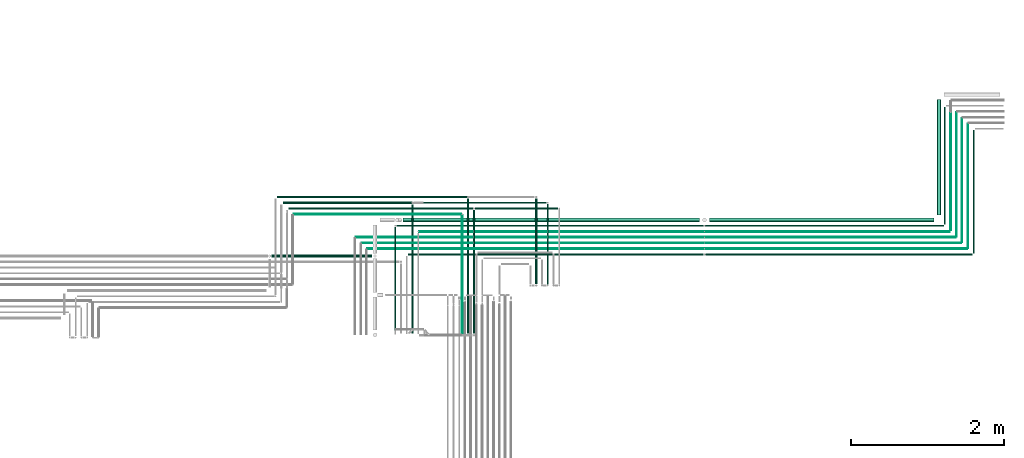
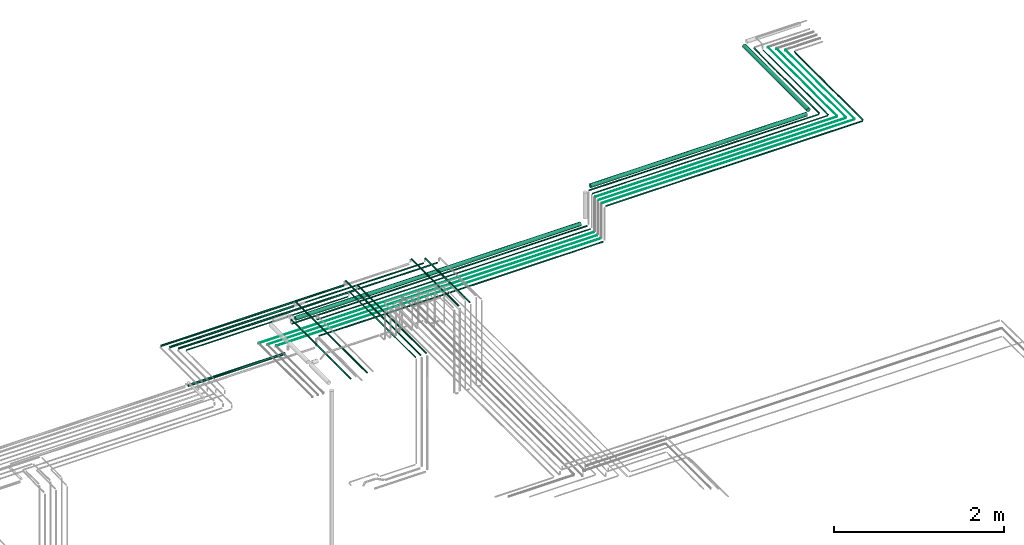
# One storey, part 26 of 65: 35 flow segments.
"""IFC2X3 building model written with IfcOpenShell, lengths in millimetres."""

from ifc_helpers import new_model, entity, si_unit, converted_unit, derived_unit, direction, frame, frame_2d, origin, origin_2d_with_axis, place, context, subcontext, project, spatial, circle, extrude, type_object, element, save


model = new_model("IFC2X3")

# Units and contexts
model_context = context("Model", 3, precision=0.01, world=origin(), true_north=direction((6.12303176911189e-17, 1.0)))
body_context = subcontext(model_context, "Body", "Model", "MODEL_VIEW")
ifc_project = project(units=[si_unit("LENGTHUNIT", "METRE", prefix="MILLI"), si_unit("AREAUNIT", "SQUARE_METRE"), si_unit("VOLUMEUNIT", "CUBIC_METRE"), converted_unit("PLANEANGLEUNIT", "DEGREE", entity("IfcRatioMeasure", 0.0174532925199433), si_unit("PLANEANGLEUNIT", "RADIAN"), dimensions=[0, 0, 0, 0, 0, 0, 0]), si_unit("MASSUNIT", "GRAM", prefix="KILO"), derived_unit("MASSDENSITYUNIT", [(si_unit("MASSUNIT", "GRAM", prefix="KILO"), 1), (si_unit("LENGTHUNIT", "METRE"), -3)]), derived_unit("MOMENTOFINERTIAUNIT", [(si_unit("LENGTHUNIT", "METRE"), 4)]), si_unit("TIMEUNIT", "SECOND"), si_unit("FREQUENCYUNIT", "HERTZ"), si_unit("THERMODYNAMICTEMPERATUREUNIT", "DEGREE_CELSIUS"), derived_unit("THERMALTRANSMITTANCEUNIT", [(si_unit("MASSUNIT", "GRAM", prefix="KILO"), 1), (si_unit("THERMODYNAMICTEMPERATUREUNIT", "KELVIN"), -1), (si_unit("TIMEUNIT", "SECOND"), -3)]), derived_unit("VOLUMETRICFLOWRATEUNIT", [(si_unit("LENGTHUNIT", "METRE"), 3), (si_unit("TIMEUNIT", "SECOND"), -1)]), derived_unit("MASSFLOWRATEUNIT", [(si_unit("MASSUNIT", "GRAM", prefix="KILO"), 1), (si_unit("TIMEUNIT", "SECOND"), -1)]), derived_unit("ROTATIONALFREQUENCYUNIT", [(si_unit("TIMEUNIT", "SECOND"), -1)]), si_unit("ELECTRICCURRENTUNIT", "AMPERE"), si_unit("ELECTRICVOLTAGEUNIT", "VOLT"), si_unit("POWERUNIT", "WATT"), si_unit("FORCEUNIT", "NEWTON", prefix="KILO"), si_unit("ILLUMINANCEUNIT", "LUX"), si_unit("LUMINOUSFLUXUNIT", "LUMEN"), si_unit("LUMINOUSINTENSITYUNIT", "CANDELA"), derived_unit("USERDEFINED", [(si_unit("MASSUNIT", "GRAM", prefix="KILO"), -1), (si_unit("LENGTHUNIT", "METRE"), -2), (si_unit("TIMEUNIT", "SECOND"), 3), (si_unit("LUMINOUSFLUXUNIT", "LUMEN"), 1)]), derived_unit("LINEARVELOCITYUNIT", [(si_unit("LENGTHUNIT", "METRE"), 1), (si_unit("TIMEUNIT", "SECOND"), -1)]), si_unit("PRESSUREUNIT", "PASCAL"), derived_unit("USERDEFINED", [(si_unit("LENGTHUNIT", "METRE"), -2), (si_unit("MASSUNIT", "GRAM", prefix="KILO"), 1), (si_unit("TIMEUNIT", "SECOND"), -2)]), derived_unit("LINEARFORCEUNIT", [(si_unit("MASSUNIT", "GRAM", prefix="KILO"), 1), (si_unit("LENGTHUNIT", "METRE"), 1), (si_unit("TIMEUNIT", "SECOND"), -2), (si_unit("LENGTHUNIT", "METRE"), -1)]), derived_unit("PLANARFORCEUNIT", [(si_unit("MASSUNIT", "GRAM", prefix="KILO"), 1), (si_unit("LENGTHUNIT", "METRE"), 1), (si_unit("TIMEUNIT", "SECOND"), -2), (si_unit("LENGTHUNIT", "METRE"), -2)])], contexts=[model_context])

# Site, building, storey
site_placement = place(None, frame((0.0, -0.00077364408347762, 0.0)))
site = spatial("IfcSite", under=ifc_project, at=site_placement, CompositionType="ELEMENT")
building_placement = place(site_placement, origin())
building = spatial("IfcBuilding", under=site, at=building_placement, CompositionType="ELEMENT")
storey_placement = place(building_placement, frame((0.0, 0.0, 19800.0)))
storey = spatial("IfcBuildingStorey", under=building, at=storey_placement, CompositionType="ELEMENT", Elevation=19800.0)

# Flow segments
pipe_segment_type = type_object("IfcPipeSegmentType", PredefinedType="NOTDEFINED")
flow_segment_1_placement = place(storey_placement, frame((72891.0813574749, 8737.87074191412, 3040.90472776409)))
element("IfcFlowSegment", 1, at=flow_segment_1_placement, inside=storey, type_object=pipe_segment_type, context=body_context, shape_type="SweptSolid", body=[
    extrude(circle(Radius=7.5, at=frame_2d((8.66293703438714e-12, 0.0), x_axis=(1.0, 0.0))), frame((9.09527223592286, 0.0, 9.09527223591419), z_axis=(0.0, 1.0, 0.0), x_axis=(-1.0, 0.0, 0.0)), (0.0, 0.0, 1.0), 1604.00000000001),
])
flow_segment_2_placement = place(storey_placement, frame((65518.1118832776, 8710.77546967822, 2540.90472776407)))
element("IfcFlowSegment", 2, at=flow_segment_2_placement, inside=storey, type_object=pipe_segment_type, context=body_context, shape_type="SweptSolid", body=[
    extrude(circle(Radius=7.5, at=frame_2d((-1.19115384222823e-11, 0.0), x_axis=(1.0, 0.0))), frame((0.0, 9.09527223592719, 9.09527223591419), z_axis=(1.0, 0.0, 0.0), x_axis=(0.0, 1.0, 0.0)), (0.0, 0.0, 1.0), 3851.41924861261),
])
flow_segment_3_placement = place(storey_placement, frame((69405.5311318902, 8710.7754696782, 3040.90472776409)))
element("IfcFlowSegment", 3, at=flow_segment_3_placement, inside=storey, type_object=pipe_segment_type, context=body_context, shape_type="SweptSolid", body=[
    extrude(circle(Radius=7.5, at=frame_2d((-5.41433564649196e-12, 0.0), x_axis=(1.0, 0.0))), frame((0.0, 9.09527223592177, 9.09527223591419), z_axis=(1.0, 0.0, 0.0), x_axis=(0.0, 1.0, 0.0)), (0.0, 0.0, 1.0), 3476.6454978206),
])
flow_segment_4_placement = place(storey_placement, frame((66287.5166110417, 7689.14924983326, 2612.40472776409)))
element("IfcFlowSegment", 4, at=flow_segment_4_placement, inside=storey, type_object=pipe_segment_type, context=body_context, shape_type="SweptSolid", body=[
    extrude(circle(Radius=11.0, at=origin_2d_with_axis()), frame((12.5952722359307, 0.0, 12.5952722359177), z_axis=(0.0, 1.0, 0.0), x_axis=(1.0, 0.0, 0.0)), (0.0, 0.0, 1.0), 1756.30342164308),
])
flow_segment_5_placement = place(storey_placement, frame((67177.5166110417, 8339.14924977606, 2612.4047277641)))
element("IfcFlowSegment", 5, at=flow_segment_5_placement, inside=storey, type_object=pipe_segment_type, context=body_context, shape_type="SweptSolid", body=[
    extrude(circle(Radius=11.0, at=frame_2d((0.0, -4.33146851719357e-12), x_axis=(1.0, 0.0))), frame((12.5952722359134, 0.0, 12.5952722359134), z_axis=(0.0, 1.0, 0.0), x_axis=(1.0, 0.0, 0.0)), (0.0, 0.0, 1.0), 1106.30342170028),
])
flow_segment_6_placement = place(storey_placement, frame((72819.5813574749, 8804.45267147632, 3044.40472776409)))
element("IfcFlowSegment", 6, at=flow_segment_6_placement, inside=storey, type_object=pipe_segment_type, context=body_context, shape_type="SweptSolid", body=[
    extrude(circle(Radius=4.0, at=frame_2d((8.66293703438714e-12, 0.0), x_axis=(1.0, 0.0))), frame((5.59527223592365, 0.0, 5.59527223591499), z_axis=(0.0, 1.0, 0.0), x_axis=(-1.0, 0.0, 0.0)), (0.0, 0.0, 1.0), 1620.00000000001),
])
flow_segment_7_placement = place(storey_placement, frame((69395.8929569255, 8788.85739924041, 3044.40472776409)))
element("IfcFlowSegment", 7, at=flow_segment_7_placement, inside=storey, type_object=pipe_segment_type, context=body_context, shape_type="SweptSolid", body=[
    extrude(circle(Radius=4.0, at=frame_2d((-7.58006990508875e-12, 0.0), x_axis=(1.0, 0.0))), frame((0.0, 5.59527223592365, 5.59527223591499), z_axis=(1.0, 0.0, 0.0), x_axis=(0.0, 1.0, 0.0)), (0.0, 0.0, 1.0), 3419.28367278529),
])
flow_segment_8_placement = place(storey_placement, frame((72744.5813574749, 8879.45267147632, 3044.40472776409)))
element("IfcFlowSegment", 8, at=flow_segment_8_placement, inside=storey, type_object=pipe_segment_type, context=body_context, shape_type="SweptSolid", body=[
    extrude(circle(Radius=4.0, at=frame_2d((2.59888111031614e-11, 0.0), x_axis=(1.0, 0.0))), frame((5.59527223594098, 0.0, 5.59527223591499), z_axis=(0.0, 1.0, 0.0), x_axis=(-1.0, 0.0, 0.0)), (0.0, 0.0, 1.0), 1620.24322646966),
])
flow_segment_9_placement = place(storey_placement, frame((69395.8929569256, 8863.85739924041, 3044.40472776409)))
element("IfcFlowSegment", 9, at=flow_segment_9_placement, inside=storey, type_object=pipe_segment_type, context=body_context, shape_type="SweptSolid", body=[
    extrude(circle(Radius=4.0, at=frame_2d((-1.08286712929839e-11, 0.0), x_axis=(1.0, 0.0))), frame((0.0, 5.5952722359269, 5.59527223591499), z_axis=(1.0, 0.0, 0.0), x_axis=(0.0, 1.0, 0.0)), (0.0, 0.0, 1.0), 3344.2836727853),
])
flow_segment_10_placement = place(storey_placement, frame((64985.1118832776, 8788.85739924042, 2544.40472776408)))
element("IfcFlowSegment", 10, at=flow_segment_10_placement, inside=storey, type_object=pipe_segment_type, context=body_context, shape_type="SweptSolid", body=[
    extrude(circle(Radius=4.0, at=frame_2d((-9.74580416368554e-12, 0.0), x_axis=(1.0, 0.0))), frame((0.0, 5.59527223592582, 5.59527223591499), z_axis=(1.0, 0.0, 0.0), x_axis=(0.0, 1.0, 0.0)), (0.0, 0.0, 1.0), 4390.78107364791),
])
flow_segment_11_placement = place(storey_placement, frame((64910.1118832776, 8863.85739924042, 2544.40472776408)))
element("IfcFlowSegment", 11, at=flow_segment_11_placement, inside=storey, type_object=pipe_segment_type, context=body_context, shape_type="SweptSolid", body=[
    extrude(circle(Radius=4.0, at=frame_2d((-9.74580416368554e-12, 0.0), x_axis=(1.0, 0.0))), frame((0.0, 5.59527223592582, 5.59527223591499), z_axis=(1.0, 0.0, 0.0), x_axis=(0.0, 1.0, 0.0)), (0.0, 0.0, 1.0), 4465.78107364791),
])
flow_segment_12_placement = place(storey_placement, frame((72669.5813574748, 8954.45267147632, 3044.40472776409)))
element("IfcFlowSegment", 12, at=flow_segment_12_placement, inside=storey, type_object=pipe_segment_type, context=body_context, shape_type="SweptSolid", body=[
    extrude(circle(Radius=4.0, at=frame_2d((4.33146851719357e-11, 0.0), x_axis=(1.0, 0.0))), frame((5.59527223594964, 0.0, 5.59527223591499), z_axis=(0.0, 1.0, 0.0), x_axis=(-1.0, 0.0, 0.0)), (0.0, 0.0, 1.0), 1620.4876689227),
])
flow_segment_13_placement = place(storey_placement, frame((69395.8929569256, 8938.8573992404, 3044.40472776409)))
element("IfcFlowSegment", 13, at=flow_segment_13_placement, inside=storey, type_object=pipe_segment_type, context=body_context, shape_type="SweptSolid", body=[
    extrude(circle(Radius=4.0, at=origin_2d_with_axis()), frame((0.0, 5.59527223593881, 5.59527223591499), z_axis=(1.0, 0.0, 0.0), x_axis=(0.0, -1.0, 0.0)), (0.0, 0.0, 1.0), 3269.28367278529),
])
flow_segment_14_placement = place(storey_placement, frame((64835.1118832776, 8938.85739924042, 2544.40472776408)))
element("IfcFlowSegment", 14, at=flow_segment_14_placement, inside=storey, type_object=pipe_segment_type, context=body_context, shape_type="SweptSolid", body=[
    extrude(circle(Radius=4.0, at=frame_2d((-1.19115384222823e-11, 0.0), x_axis=(1.0, 0.0))), frame((0.0, 5.59527223592907, 5.59527223591499), z_axis=(1.0, 0.0, 0.0), x_axis=(0.0, 1.0, 0.0)), (0.0, 0.0, 1.0), 4540.78107364791),
])
flow_segment_15_placement = place(storey_placement, frame((69450.8929569255, 9140.8573992404, 3021.4047277641)))
element("IfcFlowSegment", 15, at=flow_segment_15_placement, inside=storey, type_object=pipe_segment_type, context=body_context, shape_type="SweptSolid", body=[
    extrude(circle(Radius=27.0, at=origin_2d_with_axis()), frame((0.0, 28.595272235939, 28.5952722359141), z_axis=(1.0, 0.0, 0.0), x_axis=(0.0, -1.0, 0.0)), (0.0, 0.0, 1.0), 2934.28367278527),
])
flow_segment_16_placement = place(storey_placement, frame((65451.4218217537, 9140.85739924042, 2521.40472776407)))
element("IfcFlowSegment", 16, at=flow_segment_16_placement, inside=storey, type_object=pipe_segment_type, context=body_context, shape_type="SweptSolid", body=[
    extrude(circle(Radius=27.0, at=frame_2d((-2.16573425859679e-12, 0.0), x_axis=(1.0, 0.0))), frame((0.0, 28.5952722359173, 28.5952722359141), z_axis=(1.0, 0.0, 0.0), x_axis=(0.0, 1.0, 0.0)), (0.0, 0.0, 1.0), 3869.47113517186),
])
flow_segment_17_placement = place(storey_placement, frame((72421.5813574749, 9234.45267147632, 3021.40472776409)))
element("IfcFlowSegment", 17, at=flow_segment_17_placement, inside=storey, type_object=pipe_segment_type, context=body_context, shape_type="SweptSolid", body=[
    extrude(circle(Radius=27.0, at=origin_2d_with_axis()), frame((28.5952722359184, 0.0, 28.5952722359141), z_axis=(0.0, 1.0, 0.0), x_axis=(-1.0, 0.0, 0.0)), (0.0, 0.0, 1.0), 1510.29724665513),
])
flow_segment_18_placement = place(storey_placement, frame((72516.0813574748, 9112.45267147631, 3040.90472776408)))
element("IfcFlowSegment", 18, at=flow_segment_18_placement, inside=storey, type_object=pipe_segment_type, context=body_context, shape_type="SweptSolid", body=[
    extrude(circle(Radius=7.5, at=frame_2d((5.19776222063229e-11, 0.0), x_axis=(1.0, 0.0))), frame((9.09527223596617, 0.0, 9.09527223591419), z_axis=(0.0, 1.0, 0.0), x_axis=(-1.0, 0.0, 0.0)), (0.0, 0.0, 1.0), 1529.421059575),
])
flow_segment_19_placement = place(storey_placement, frame((72592.5813574748, 9033.45267147631, 3042.40472776407)))
element("IfcFlowSegment", 19, at=flow_segment_19_placement, inside=storey, type_object=pipe_segment_type, context=body_context, shape_type="SweptSolid", body=[
    extrude(circle(Radius=6.0, at=frame_2d((4.33146851719357e-11, 0.0), x_axis=(1.0, 0.0))), frame((7.59527223595785, 0.0, 7.59527223591454), z_axis=(0.0, 1.0, 0.0), x_axis=(-1.0, 0.0, 0.0)), (0.0, 0.0, 1.0), 1527.48766892272),
])
flow_segment_20_placement = place(storey_placement, frame((69395.8929569255, 9011.8573992404, 3042.40472776409)))
element("IfcFlowSegment", 20, at=flow_segment_20_placement, inside=storey, type_object=pipe_segment_type, context=body_context, shape_type="SweptSolid", body=[
    extrude(circle(Radius=6.0, at=origin_2d_with_axis()), frame((0.0, 7.59527223594161, 7.59527223591454), z_axis=(1.0, 0.0, 0.0), x_axis=(0.0, -1.0, 0.0)), (0.0, 0.0, 1.0), 3190.28367278531),
])
flow_segment_21_placement = place(storey_placement, frame((69395.8929569255, 9085.3573992404, 3040.90472776409)))
element("IfcFlowSegment", 21, at=flow_segment_21_placement, inside=storey, type_object=pipe_segment_type, context=body_context, shape_type="SweptSolid", body=[
    extrude(circle(Radius=7.5, at=origin_2d_with_axis()), frame((0.0, 9.09527223594452, 9.09527223591419), z_axis=(1.0, 0.0, 0.0), x_axis=(0.0, -1.0, 0.0)), (0.0, 0.0, 1.0), 3111.2836727853),
])
flow_segment_22_placement = place(storey_placement, frame((65664.1118832777, 9011.85739924042, 2542.40472776407)))
element("IfcFlowSegment", 22, at=flow_segment_22_placement, inside=storey, type_object=pipe_segment_type, context=body_context, shape_type="SweptSolid", body=[
    extrude(circle(Radius=6.0, at=frame_2d((-9.74580416368554e-12, 0.0), x_axis=(1.0, 0.0))), frame((0.0, 7.59527223592645, 7.59527223591454), z_axis=(1.0, 0.0, 0.0), x_axis=(0.0, 1.0, 0.0)), (0.0, 0.0, 1.0), 3707.7810736479),
])
flow_segment_23_placement = place(storey_placement, frame((65368.1118832776, 9085.35739924042, 2540.90472776408)))
element("IfcFlowSegment", 23, at=flow_segment_23_placement, inside=storey, type_object=pipe_segment_type, context=body_context, shape_type="SweptSolid", body=[
    extrude(circle(Radius=7.5, at=frame_2d((-9.74580416368554e-12, 0.0), x_axis=(1.0, 0.0))), frame((0.0, 9.09527223592611, 9.09527223591419), z_axis=(1.0, 0.0, 0.0), x_axis=(0.0, 1.0, 0.0)), (0.0, 0.0, 1.0), 3999.78107364791),
])
flow_segment_24_placement = place(storey_placement, frame((65341.0166110417, 7683.14924977609, 2615.9047277641)))
element("IfcFlowSegment", 24, at=flow_segment_24_placement, inside=storey, type_object=pipe_segment_type, context=body_context, shape_type="SweptSolid", body=[
    extrude(circle(Radius=7.5, at=origin_2d_with_axis()), frame((9.09527223591419, 0.0, 9.09527223591419), z_axis=(0.0, 1.0, 0.0), x_axis=(1.0, 0.0, 0.0)), (0.0, 0.0, 1.0), 1393.30342170028),
])
flow_segment_25_placement = place(storey_placement, frame((66217.5166110417, 7679.14924983326, 2617.40472776411)))
element("IfcFlowSegment", 25, at=flow_segment_25_placement, inside=storey, type_object=pipe_segment_type, context=body_context, shape_type="SweptSolid", body=[
    extrude(circle(Radius=6.0, at=origin_2d_with_axis()), frame((7.59527223591454, 0.0, 7.59527223591454), z_axis=(0.0, 1.0, 0.0), x_axis=(1.0, 0.0, 0.0)), (0.0, 0.0, 1.0), 1551.30342164308),
])
flow_segment_26_placement = place(storey_placement, frame((65562.5166110418, 7689.14924977607, 2612.4047277641)))
element("IfcFlowSegment", 26, at=flow_segment_26_placement, inside=storey, type_object=pipe_segment_type, context=body_context, shape_type="SweptSolid", body=[
    extrude(circle(Radius=11.0, at=frame_2d((-8.66293703438714e-12, 0.0), x_axis=(1.0, 0.0))), frame((12.5952722359047, 0.0, 12.5952722359177), z_axis=(0.0, 1.0, 0.0), x_axis=(-1.0, 0.0, 0.0)), (0.0, 0.0, 1.0), 1681.30342170027),
])
flow_segment_27_placement = place(storey_placement, frame((66362.5166110418, 7689.14924983325, 2612.4047277641)))
element("IfcFlowSegment", 27, at=flow_segment_27_placement, inside=storey, type_object=pipe_segment_type, context=body_context, shape_type="SweptSolid", body=[
    extrude(circle(Radius=11.0, at=origin_2d_with_axis()), frame((12.5952722359134, 0.0, 12.5952722359177), z_axis=(0.0, 1.0, 0.0), x_axis=(1.0, 0.0, 0.0)), (0.0, 0.0, 1.0), 1606.30342164309),
])
flow_segment_28_placement = place(storey_placement, frame((67331.0166110417, 8333.14924977606, 2615.9047277641)))
element("IfcFlowSegment", 28, at=flow_segment_28_placement, inside=storey, type_object=pipe_segment_type, context=body_context, shape_type="SweptSolid", body=[
    extrude(circle(Radius=7.5, at=origin_2d_with_axis()), frame((9.09527223591419, 0.0, 9.09527223591419), z_axis=(0.0, 1.0, 0.0), x_axis=(1.0, 0.0, 0.0)), (0.0, 0.0, 1.0), 1043.30342170028),
])
flow_segment_29_placement = place(storey_placement, frame((66395.1118832777, 9310.35739924043, 2540.90472776409)))
element("IfcFlowSegment", 29, at=flow_segment_29_placement, inside=storey, type_object=pipe_segment_type, context=body_context, shape_type="SweptSolid", body=[
    extrude(circle(Radius=7.5, at=frame_2d((-1.08286712929839e-12, 0.0), x_axis=(1.0, 0.0))), frame((0.0, 9.09527223591744, 9.09527223591419), z_axis=(1.0, 0.0, 0.0), x_axis=(0.0, 1.0, 0.0)), (0.0, 0.0, 1.0), 1076.99999999997),
])
flow_segment_30_placement = place(storey_placement, frame((65720.1118832776, 9385.35739924041, 2540.90472776409)))
element("IfcFlowSegment", 30, at=flow_segment_30_placement, inside=storey, type_object=pipe_segment_type, context=body_context, shape_type="SweptSolid", body=[
    extrude(circle(Radius=7.5, at=frame_2d((4.33146851719357e-12, 0.0), x_axis=(1.0, 0.0))), frame((0.0, 9.09527223592069, 9.09527223591419), z_axis=(1.0, 0.0, 0.0), x_axis=(0.0, 1.0, 0.0)), (0.0, 0.0, 1.0), 1602.00000000002),
])
flow_segment_31_placement = place(storey_placement, frame((63731.0593442443, 8680.90493375773, 2455.90472776407)))
element("IfcFlowSegment", 31, at=flow_segment_31_placement, inside=storey, type_object=pipe_segment_type, context=body_context, shape_type="SweptSolid", body=[
    extrude(circle(Radius=17.5, at=frame_2d((3.24860138789518e-12, 0.0), x_axis=(1.0, 0.0))), frame((0.0, 19.0952722359195, 19.0952722359163), z_axis=(1.0, 0.0, 0.0), x_axis=(0.0, 1.0, 0.0)), (0.0, 0.0, 1.0), 1314.05253903331),
])
flow_segment_32_placement = place(storey_placement, frame((63959.0593442443, 9306.85739924043, 2537.40472776408)))
element("IfcFlowSegment", 32, at=flow_segment_32_placement, inside=storey, type_object=pipe_segment_type, context=body_context, shape_type="SweptSolid", body=[
    extrude(circle(Radius=11.0, at=frame_2d((-1.08286712929839e-12, 0.0), x_axis=(1.0, 0.0))), frame((0.0, 12.5952722359166, 12.5952722359177), z_axis=(1.0, 0.0, 0.0), x_axis=(0.0, 1.0, 0.0)), (0.0, 0.0, 1.0), 2404.05253903335),
])
flow_segment_33_placement = place(storey_placement, frame((63809.0593442444, 9456.85739924043, 2537.40472776408)))
element("IfcFlowSegment", 33, at=flow_segment_33_placement, inside=storey, type_object=pipe_segment_type, context=body_context, shape_type="SweptSolid", body=[
    extrude(circle(Radius=11.0, at=origin_2d_with_axis()), frame((0.0, 12.5952722359156, 12.5952722359177), z_axis=(1.0, 0.0, 0.0), x_axis=(0.0, 1.0, 0.0)), (0.0, 0.0, 1.0), 2479.05253903331),
])
flow_segment_34_placement = place(storey_placement, frame((64024.0593442443, 9236.85739924044, 2542.40472776409)))
element("IfcFlowSegment", 34, at=flow_segment_34_placement, inside=storey, type_object=pipe_segment_type, context=body_context, shape_type="SweptSolid", body=[
    extrude(circle(Radius=6.0, at=origin_2d_with_axis()), frame((0.0, 7.59527223591562, 7.59527223591454), z_axis=(1.0, 0.0, 0.0), x_axis=(0.0, 1.0, 0.0)), (0.0, 0.0, 1.0), 2187.05253903333),
])
flow_segment_35_placement = place(storey_placement, frame((63884.0593442443, 9381.85739924043, 2537.40472776408)))
element("IfcFlowSegment", 35, at=flow_segment_35_placement, inside=storey, type_object=pipe_segment_type, context=body_context, shape_type="SweptSolid", body=[
    extrude(circle(Radius=11.0, at=origin_2d_with_axis()), frame((0.0, 12.5952722359156, 12.5952722359177), z_axis=(1.0, 0.0, 0.0), x_axis=(0.0, -1.0, 0.0)), (0.0, 0.0, 1.0), 1679.05253903333),
])

save(model, "model.ifc")
